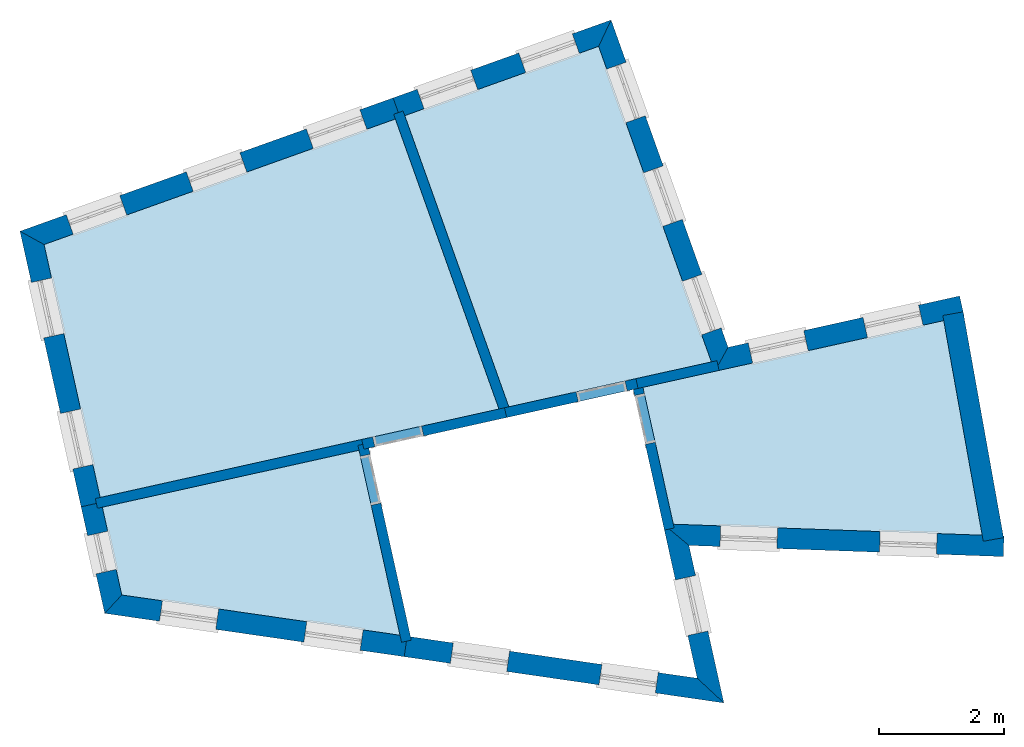
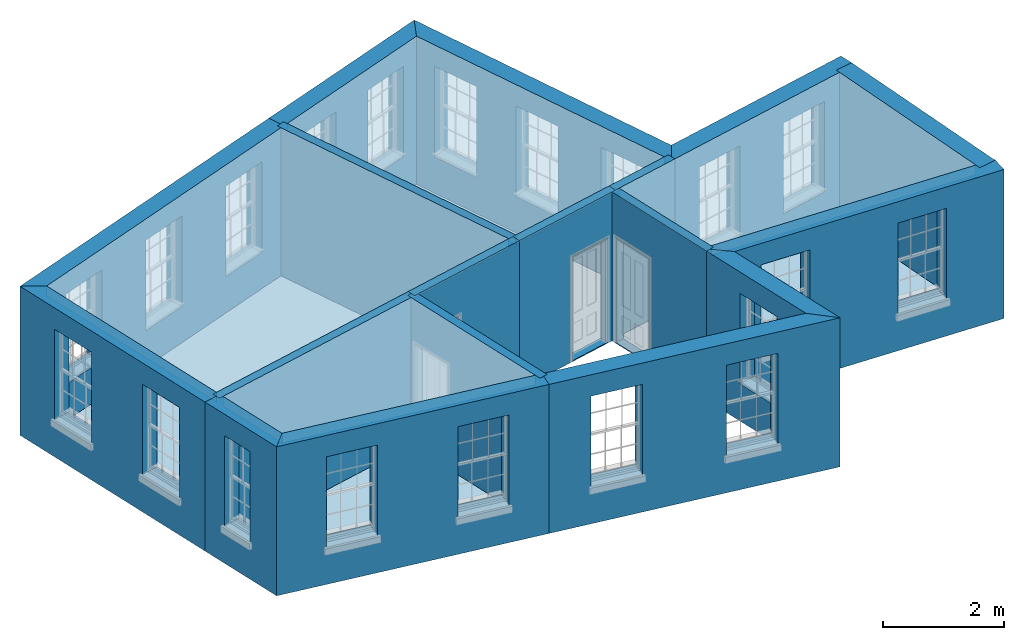
# One storey, part 1 of 10: 18 walls, 8 slabs, 24 openings.
"""IFC2X3 building model written with IfcOpenShell, lengths in metres."""

from ifc_helpers import new_model, si_unit, frame, origin, place, context, subcontext, project, spatial, polyline, outline, extrude, material, layer, layer_set, layer_usage, element, save


model = new_model("IFC2X3")

# Units and contexts
model_context = context("Model", 3, world=origin())
body_context = subcontext(model_context, "Body", "Model", "MODEL_VIEW")
ifc_project = project(units=[si_unit("PLANEANGLEUNIT", "RADIAN"), si_unit("MASSUNIT", "GRAM", prefix="KILO"), si_unit("FORCEUNIT", "NEWTON", prefix="KILO"), si_unit("LENGTHUNIT", "METRE")], contexts=[model_context])

# Site, building, storey
site_placement = place(None, origin())
site = spatial("IfcSite", under=ifc_project, at=site_placement, CompositionType="ELEMENT")
building_placement = place(None, origin())
building = spatial("IfcBuilding", under=site, at=building_placement, Name="Building plot-16", CompositionType="ELEMENT")
storey_placement = place(None, frame((0.0, 0.0, 6.0)))
storey = spatial("IfcBuildingStorey", under=building, at=storey_placement, Name="Floor 1", CompositionType="ELEMENT", Elevation=6.0)

# Slabs
slab_1_placement = place(storey_placement, frame((0.0, 0.0, 2.8)))
element("IfcSlab", 1, at=slab_1_placement, inside=storey, Name="Slab", ObjectType="Slab", PredefinedType="FLOOR", context=body_context, shape_type="SweptSolid", body=[
    extrude(outline(polyline([(96.2866198222254, 35.3957755660827), (96.7722962804905, 33.2056967986451), (101.713566305505, 33.029896488782), (101.098558041472, 36.4628810722689), (96.2866198222254, 35.3957755660827)])), origin(), (0.0, 0.0, 1.0), 0.2),
])
slab_2_placement = place(storey_placement, frame((0.0, 0.0, 2.8)))
element("IfcSlab", 2, at=slab_2_placement, inside=storey, Name="Slab", ObjectType="Slab", PredefinedType="FLOOR", context=body_context, shape_type="SweptSolid", body=[
    extrude(outline(polyline([(94.1404528776861, 35.0837241435856), (97.3810072176828, 35.8023562668068), (95.5770005534573, 40.8505427478087), (92.4756885775016, 39.7422660441802), (94.1404528776861, 35.0837241435856)])), origin(), (0.0, 0.0, 1.0), 0.2),
])
slab_3_placement = place(storey_placement, frame((0.0, 0.0, 2.8)))
element("IfcSlab", 3, at=slab_3_placement, inside=storey, Name="Slab", ObjectType="Slab", PredefinedType="FLOOR", context=body_context, shape_type="SweptSolid", body=[
    extrude(outline(polyline([(87.6024611335815, 33.6338453896089), (93.9830197157487, 35.0488114355862), (92.3250201117694, 39.6884235569242), (86.7051504212186, 37.6801216821844), (87.6024611335815, 33.6338453896089)])), origin(), (0.0, 0.0, 1.0), 0.2),
])
slab_4_placement = place(storey_placement, frame((0.0, 0.0, 2.8)))
element("IfcSlab", 4, at=slab_4_placement, inside=storey, Name="Slab", ObjectType="Slab", PredefinedType="FLOOR", context=body_context, shape_type="SweptSolid", body=[
    extrude(outline(polyline([(91.7432052171659, 34.3882184194522), (87.637101511753, 33.4776402546096), (87.9484434240576, 32.0736946856034), (92.3993213504913, 31.4295697385958), (91.7432052171659, 34.3882184194522)])), origin(), (0.0, 0.0, 1.0), 0.2),
])
slab_5_placement = place(storey_placement, origin())
element("IfcSlab", 5, at=slab_5_placement, inside=storey, Name="Slab", ObjectType="Slab", PredefinedType="FLOOR", context=body_context, shape_type="SweptSolid", body=[
    extrude(outline(polyline([(96.2866198222254, 35.3957755660827), (96.7722962804905, 33.2056967986451), (101.713566305505, 33.029896488782), (101.098558041472, 36.4628810722689), (96.2866198222254, 35.3957755660827)])), origin(), (0.0, 0.0, 1.0), 0.02),
])
slab_6_placement = place(storey_placement, origin())
element("IfcSlab", 6, at=slab_6_placement, inside=storey, Name="Slab", ObjectType="Slab", PredefinedType="FLOOR", context=body_context, shape_type="SweptSolid", body=[
    extrude(outline(polyline([(94.1404528776861, 35.0837241435856), (97.3810072176828, 35.8023562668068), (95.5770005534573, 40.8505427478087), (92.4756885775016, 39.7422660441802), (94.1404528776861, 35.0837241435856)])), origin(), (0.0, 0.0, 1.0), 0.02),
])
slab_7_placement = place(storey_placement, origin())
element("IfcSlab", 7, at=slab_7_placement, inside=storey, Name="Slab", ObjectType="Slab", PredefinedType="FLOOR", context=body_context, shape_type="SweptSolid", body=[
    extrude(outline(polyline([(87.6024611335815, 33.6338453896089), (93.9830197157487, 35.0488114355862), (92.3250201117694, 39.6884235569242), (86.7051504212186, 37.6801216821844), (87.6024611335815, 33.6338453896089)])), origin(), (0.0, 0.0, 1.0), 0.02),
])
slab_8_placement = place(storey_placement, origin())
element("IfcSlab", 8, at=slab_8_placement, inside=storey, Name="Slab", ObjectType="Slab", PredefinedType="FLOOR", context=body_context, shape_type="SweptSolid", body=[
    extrude(outline(polyline([(91.7432052171659, 34.3882184194522), (87.637101511753, 33.4776402546096), (87.9484434240576, 32.0736946856034), (92.3993213504913, 31.4295697385958), (91.7432052171659, 34.3882184194522)])), origin(), (0.0, 0.0, 1.0), 0.02),
])

# Wall, openings
ifc_material_1 = material(Name="Masonry")
ifc_layer_1 = layer(ifc_material_1, 0.33, ventilated=False)
ifc_layer_set_1 = layer_set([ifc_layer_1], Name="My Wall")
ifc_layer_usage_1 = layer_usage(ifc_layer_set_1, "AXIS2", "NEGATIVE", 0.08)
wall_1_placement = place(storey_placement, origin())
wall_1 = element("IfcWallStandardCase", 9, at=wall_1_placement, inside=storey, material=ifc_layer_usage_1, Name="exterior", context=body_context, shape_type="SweptSolid", body=[
    extrude(outline(polyline([(101.423997894318, 36.5350512962164), (101.35255211434, 36.8572243871524), (97.6480557261626, 36.0357075028211), (97.435272994639, 35.6505033013804), (101.423997894318, 36.5350512962164)])), origin(), (0.0, 0.0, 1.0), 3.0),
])
opening_1_placement = place(storey_placement, frame((0.0, 0.0, 0.75)))
element("IfcOpeningElement", 10, at=opening_1_placement, cuts=wall_1, Name="Opening", ObjectType="Opening", context=body_context, shape_type="SweptSolid", body=[
    extrude(outline(polyline([(100.695978200438, 36.7116211797089), (99.8075614951299, 36.5146040288589), (99.8790072751085, 36.1924309379229), (100.767423980417, 36.3894480887729), (100.695978200438, 36.7116211797089)])), origin(), (0.0, 0.0, 1.0), 1.82),
])
opening_2_placement = place(storey_placement, frame((0.0, 0.0, 0.75)))
element("IfcOpeningElement", 11, at=opening_2_placement, cuts=wall_1, Name="Opening", ObjectType="Opening", context=body_context, shape_type="SweptSolid", body=[
    extrude(outline(polyline([(98.8581029531051, 36.304050112344), (97.9696862477967, 36.107032961494), (98.0411320277753, 35.784859870558), (98.9295487330837, 35.981877021408), (98.8581029531051, 36.304050112344)])), origin(), (0.0, 0.0, 1.0), 1.82),
])

wall_2_placement = place(storey_placement, origin())
wall_2 = element("IfcWallStandardCase", 12, at=wall_2_placement, inside=storey, material=ifc_layer_usage_1, Name="exterior", context=body_context, shape_type="SweptSolid", body=[
    extrude(outline(polyline([(97.435272994639, 35.6505033013804), (97.6480557261626, 36.0357075028211), (95.7767041340643, 41.2723465883469), (95.5770005534573, 40.8505427478087), (97.435272994639, 35.6505033013804)])), origin(), (0.0, 0.0, 1.0), 3.0),
])
opening_3_placement = place(storey_placement, frame((0.0, 0.0, 0.75)))
element("IfcOpeningElement", 13, at=opening_3_placement, cuts=wall_2, Name="Opening", ObjectType="Opening", context=body_context, shape_type="SweptSolid", body=[
    extrude(outline(polyline([(97.5371926148935, 36.3459378753852), (97.2309634686248, 37.2028647742368), (96.9202097580522, 37.0918146442713), (97.2264389043209, 36.2348877454196), (97.5371926148935, 36.3459378753852)])), origin(), (0.0, 0.0, 1.0), 1.82),
])
opening_4_placement = place(storey_placement, frame((0.0, 0.0, 0.75)))
element("IfcOpeningElement", 14, at=opening_4_placement, cuts=wall_2, Name="Opening", ObjectType="Opening", context=body_context, shape_type="SweptSolid", body=[
    extrude(outline(polyline([(96.9167115667487, 38.0822419041217), (96.61048242048, 38.9391688029733), (96.2997287099074, 38.8281186730078), (96.6059578561762, 37.9711917741561), (96.9167115667487, 38.0822419041217)])), origin(), (0.0, 0.0, 1.0), 1.82),
])
opening_5_placement = place(storey_placement, frame((0.0, 0.0, 0.75)))
element("IfcOpeningElement", 15, at=opening_5_placement, cuts=wall_2, Name="Opening", ObjectType="Opening", context=body_context, shape_type="SweptSolid", body=[
    extrude(outline(polyline([(96.3241881176086, 39.7403116468463), (96.0179589713399, 40.5972385456979), (95.7072052607673, 40.4861884157324), (96.013434407036, 39.6292615168807), (96.3241881176086, 39.7403116468463)])), origin(), (0.0, 0.0, 1.0), 1.82),
])

wall_3_placement = place(storey_placement, origin())
wall_3 = element("IfcWallStandardCase", 16, at=wall_3_placement, inside=storey, material=ifc_layer_usage_1, Name="exterior", context=body_context, shape_type="SweptSolid", body=[
    extrude(outline(polyline([(95.5770005534573, 40.8505427478087), (95.7767041340643, 41.2723465883469), (92.2893042146699, 40.0260985111248), (92.4003543446355, 39.7153448005522), (95.5770005534573, 40.8505427478087)])), origin(), (0.0, 0.0, 1.0), 3.0),
])
opening_6_placement = place(storey_placement, frame((0.0, 0.0, 0.75)))
element("IfcOpeningElement", 17, at=opening_6_placement, cuts=wall_3, Name="Opening", ObjectType="Opening", context=body_context, shape_type="SweptSolid", body=[
    extrude(outline(polyline([(95.1567529953617, 41.0508024774225), (94.29982609651, 40.7445733311538), (94.4108762264756, 40.4338196205812), (95.2678031253273, 40.74004876685), (95.1567529953617, 41.0508024774225)])), origin(), (0.0, 0.0, 1.0), 1.82),
])
opening_7_placement = place(storey_placement, frame((0.0, 0.0, 0.75)))
element("IfcOpeningElement", 18, at=opening_7_placement, cuts=wall_3, Name="Opening", ObjectType="Opening", context=body_context, shape_type="SweptSolid", body=[
    extrude(outline(polyline([(93.5307627745177, 40.4697428819803), (92.6738358756661, 40.1635137357116), (92.7848860056317, 39.852760025139), (93.6418129044833, 40.1589891714077), (93.5307627745177, 40.4697428819803)])), origin(), (0.0, 0.0, 1.0), 1.82),
])

wall_4_placement = place(storey_placement, origin())
wall_4 = element("IfcWallStandardCase", 19, at=wall_4_placement, inside=storey, material=ifc_layer_usage_1, Name="exterior", context=body_context, shape_type="SweptSolid", body=[
    extrude(outline(polyline([(92.4003543446355, 39.7153448005522), (92.2893042146699, 40.0260985111248), (86.3199462197779, 37.892904413708), (86.7051504212186, 37.6801216821844), (92.4003543446355, 39.7153448005522)])), origin(), (0.0, 0.0, 1.0), 3.0),
])
opening_8_placement = place(storey_placement, frame((0.0, 0.0, 0.75)))
element("IfcOpeningElement", 20, at=opening_8_placement, cuts=wall_4, Name="Opening", ObjectType="Opening", context=body_context, shape_type="SweptSolid", body=[
    extrude(outline(polyline([(91.7574900780122, 39.8360508078019), (90.9005631791605, 39.5298216615332), (91.0116133091261, 39.2190679509606), (91.8685402079777, 39.5252970972293), (91.7574900780122, 39.8360508078019)])), origin(), (0.0, 0.0, 1.0), 1.82),
])
opening_9_placement = place(storey_placement, frame((0.0, 0.0, 0.75)))
element("IfcOpeningElement", 21, at=opening_9_placement, cuts=wall_4, Name="Opening", ObjectType="Opening", context=body_context, shape_type="SweptSolid", body=[
    extrude(outline(polyline([(89.8369349058449, 39.1497262548875), (88.9800080069932, 38.8434971086188), (89.0910581369588, 38.5327433980462), (89.9479850358105, 38.8389725443149), (89.8369349058449, 39.1497262548875)])), origin(), (0.0, 0.0, 1.0), 1.82),
])
opening_10_placement = place(storey_placement, frame((0.0, 0.0, 0.75)))
element("IfcOpeningElement", 22, at=opening_10_placement, cuts=wall_4, Name="Opening", ObjectType="Opening", context=body_context, shape_type="SweptSolid", body=[
    extrude(outline(polyline([(87.9163797336776, 38.4634017019731), (87.0594528348259, 38.1571725557044), (87.1705029647915, 37.8464188451318), (88.0274298636432, 38.1526479914005), (87.9163797336776, 38.4634017019731)])), origin(), (0.0, 0.0, 1.0), 1.82),
])

wall_5_placement = place(storey_placement, origin())
wall_5 = element("IfcWallStandardCase", 23, at=wall_5_placement, inside=storey, material=ifc_layer_usage_1, Name="exterior", context=body_context, shape_type="SweptSolid", body=[
    extrude(outline(polyline([(86.7051504212186, 37.6801216821844), (86.3199462197779, 37.892904413708), (87.2976082317312, 33.4842970421306), (87.6197813226672, 33.5557428221092), (86.7051504212186, 37.6801216821844)])), origin(), (0.0, 0.0, 1.0), 3.0),
])
opening_11_placement = place(storey_placement, frame((0.0, 0.0, 0.75)))
element("IfcOpeningElement", 24, at=opening_11_placement, cuts=wall_5, Name="Opening", ObjectType="Opening", context=body_context, shape_type="SweptSolid", body=[
    extrude(outline(polyline([(86.5016662783098, 37.0734674510234), (86.6986834291598, 36.1850507457151), (87.0208565200958, 36.2564965256937), (86.8238393692458, 37.144913231002), (86.5016662783098, 37.0734674510234)])), origin(), (0.0, 0.0, 1.0), 1.82),
])
opening_12_placement = place(storey_placement, frame((0.0, 0.0, 0.75)))
element("IfcOpeningElement", 25, at=opening_12_placement, cuts=wall_5, Name="Opening", ObjectType="Opening", context=body_context, shape_type="SweptSolid", body=[
    extrude(outline(polyline([(86.9666218636407, 34.9768260801977), (87.1636390144908, 34.0884093748893), (87.4858121054268, 34.1598551548679), (87.2887949545767, 35.0482718601763), (86.9666218636407, 34.9768260801977)])), origin(), (0.0, 0.0, 1.0), 1.82),
])

# Wall, opening
wall_6_placement = place(storey_placement, origin())
wall_6 = element("IfcWallStandardCase", 26, at=wall_6_placement, inside=storey, material=ifc_layer_usage_1, Name="exterior", context=body_context, shape_type="SweptSolid", body=[
    extrude(outline(polyline([(87.6197813226672, 33.5557428221092), (87.2976082317312, 33.4842970421306), (87.6756142911979, 31.7797403754188), (87.9484434240576, 32.0736946856034), (87.6197813226672, 33.5557428221092)])), origin(), (0.0, 0.0, 1.0), 3.0),
])
opening_13_placement = place(storey_placement, frame((0.0, 0.0, 0.75)))
element("IfcOpeningElement", 27, at=opening_13_placement, cuts=wall_6, Name="Opening", ObjectType="Opening", context=body_context, shape_type="SweptSolid", body=[
    extrude(outline(polyline([(87.4002633796378, 33.0213903972391), (87.5355773568699, 32.4112140886482), (87.8577504478059, 32.4826598686268), (87.7224364705738, 33.0928361772177), (87.4002633796378, 33.0213903972391)])), origin(), (0.0, 0.0, 1.0), 1.82),
])

# Wall, openings
wall_7_placement = place(storey_placement, origin())
wall_7 = element("IfcWallStandardCase", 28, at=wall_7_placement, inside=storey, material=ifc_layer_usage_1, Name="exterior", context=body_context, shape_type="SweptSolid", body=[
    extrude(outline(polyline([(87.9484434240576, 32.0736946856034), (87.6756142911979, 31.7797403754188), (92.4666954104416, 31.086381689099), (92.513960177979, 31.4129793647637), (87.9484434240576, 32.0736946856034)])), origin(), (0.0, 0.0, 1.0), 3.0),
])
opening_14_placement = place(storey_placement, frame((0.0, 0.0, 0.75)))
element("IfcOpeningElement", 29, at=opening_14_placement, cuts=wall_7, Name="Opening", ObjectType="Opening", context=body_context, shape_type="SweptSolid", body=[
    extrude(outline(polyline([(88.5512372257678, 31.653021425663), (89.4518550586615, 31.5226852485144), (89.4991198261989, 31.8492829241791), (88.5985019933052, 31.9796191013278), (88.5512372257678, 31.653021425663)])), origin(), (0.0, 0.0, 1.0), 1.82),
])
opening_15_placement = place(storey_placement, frame((0.0, 0.0, 0.75)))
element("IfcOpeningElement", 30, at=opening_15_placement, cuts=wall_7, Name="Opening", ObjectType="Opening", context=body_context, shape_type="SweptSolid", body=[
    extrude(outline(polyline([(90.861336737919, 31.3187069936699), (91.7619545708128, 31.1883708165212), (91.8092193383502, 31.514968492186), (90.9086015054565, 31.6453046693347), (90.861336737919, 31.3187069936699)])), origin(), (0.0, 0.0, 1.0), 1.82),
])

wall_8_placement = place(storey_placement, origin())
wall_8 = element("IfcWallStandardCase", 31, at=wall_8_placement, inside=storey, material=ifc_layer_usage_1, Name="exterior", context=body_context, shape_type="SweptSolid", body=[
    extrude(outline(polyline([(92.513960177979, 31.4129793647637), (92.4666954104416, 31.086381689099), (97.5805288405461, 30.3463147311604), (97.1549084446968, 30.7413476988825), (92.513960177979, 31.4129793647637)])), origin(), (0.0, 0.0, 1.0), 3.0),
])
opening_16_placement = place(storey_placement, frame((0.0, 0.0, 0.75)))
element("IfcOpeningElement", 32, at=opening_16_placement, cuts=wall_8, Name="Opening", ObjectType="Opening", context=body_context, shape_type="SweptSolid", body=[
    extrude(outline(polyline([(93.2052832675461, 30.979494267745), (94.1059011004399, 30.8491580905963), (94.1531658679773, 31.1757557662611), (93.2525480350835, 31.3060919434098), (93.2052832675461, 30.979494267745)])), origin(), (0.0, 0.0, 1.0), 1.82),
])
opening_17_placement = place(storey_placement, frame((0.0, 0.0, 0.75)))
element("IfcOpeningElement", 33, at=opening_17_placement, cuts=wall_8, Name="Opening", ObjectType="Opening", context=body_context, shape_type="SweptSolid", body=[
    extrude(outline(polyline([(95.5830768146488, 30.6353832478883), (96.4836946475426, 30.5050470707397), (96.53095941508, 30.8316447464044), (95.6303415821863, 30.9619809235531), (95.5830768146488, 30.6353832478883)])), origin(), (0.0, 0.0, 1.0), 1.82),
])

# Wall, opening
wall_9_placement = place(storey_placement, origin())
wall_9 = element("IfcWallStandardCase", 34, at=wall_9_placement, inside=storey, material=ifc_layer_usage_1, Name="exterior", context=body_context, shape_type="SweptSolid", body=[
    extrude(outline(polyline([(97.1549084446968, 30.7413476988825), (97.5805288405461, 30.3463147311604), (97.0216212073761, 32.8666175367297), (96.607105896403, 33.2115739356083), (97.1549084446968, 30.7413476988825)])), origin(), (0.0, 0.0, 1.0), 3.0),
])
opening_18_placement = place(storey_placement, frame((0.0, 0.0, 0.75)))
element("IfcOpeningElement", 35, at=opening_18_placement, cuts=wall_9, Name="Opening", ObjectType="Opening", context=body_context, shape_type="SweptSolid", body=[
    extrude(outline(polyline([(97.3254209005413, 31.496682374684), (97.1284037496912, 32.3850990799923), (96.8062306587552, 32.3136533000138), (97.0032478096053, 31.4252365947054), (97.3254209005413, 31.496682374684)])), origin(), (0.0, 0.0, 1.0), 1.82),
])

# Wall, openings
wall_10_placement = place(storey_placement, origin())
wall_10 = element("IfcWallStandardCase", 36, at=wall_10_placement, inside=storey, material=ifc_layer_usage_1, Name="exterior", context=body_context, shape_type="SweptSolid", body=[
    extrude(outline(polyline([(96.607105896403, 33.2115739356083), (97.0216212073761, 32.8666175367297), (102.050747108567, 32.6876914939727), (102.06248041193, 33.0174828364791), (96.607105896403, 33.2115739356083)])), origin(), (0.0, 0.0, 1.0), 3.0),
])
opening_19_placement = place(storey_placement, frame((0.0, 0.0, 0.75)))
element("IfcOpeningElement", 37, at=opening_19_placement, cuts=wall_10, Name="Opening", ObjectType="Opening", context=body_context, shape_type="SweptSolid", body=[
    extrude(outline(polyline([(97.5195431828704, 32.8489024883441), (98.4289677940245, 32.8165470154335), (98.4407010973877, 33.14633835794), (97.5312764862336, 33.1786938308505), (97.5195431828704, 32.8489024883441)])), origin(), (0.0, 0.0, 1.0), 1.82),
])
opening_20_placement = place(storey_placement, frame((0.0, 0.0, 0.75)))
element("IfcOpeningElement", 38, at=opening_20_placement, cuts=wall_10, Name="Opening", ObjectType="Opening", context=body_context, shape_type="SweptSolid", body=[
    extrude(outline(polyline([(100.070642978856, 32.7581395605228), (100.98006759001, 32.7257840876123), (100.991800893373, 33.0555754301187), (100.082376282219, 33.0879309030292), (100.070642978856, 32.7581395605228)])), origin(), (0.0, 0.0, 1.0), 1.82),
])

# Wall
wall_11_placement = place(storey_placement, origin())
element("IfcWallStandardCase", 39, at=wall_11_placement, inside=storey, material=ifc_layer_usage_1, Name="party", context=body_context, shape_type="SweptSolid", body=[
    extrude(outline(polyline([(101.731047695816, 32.9323151277738), (102.055876401091, 32.9905071566866), (101.408689534277, 36.6031131432117), (101.083860829002, 36.5449211142989), (101.731047695816, 32.9323151277738)])), origin(), (0.0, 0.0, 1.0), 3.0),
])

# Wall, opening
ifc_material_2 = material(Name="Masonry")
ifc_layer_2 = layer(ifc_material_2, 0.16, ventilated=False)
ifc_layer_set_2 = layer_set([ifc_layer_2], Name="My Wall")
ifc_layer_usage_2 = layer_usage(ifc_layer_set_2, "AXIS2", "NEGATIVE", 0.08)
wall_12_placement = place(storey_placement, origin())
wall_12 = element("IfcWallStandardCase", 40, at=wall_12_placement, inside=storey, material=ifc_layer_usage_2, Name="interior", context=body_context, shape_type="SweptSolid", body=[
    extrude(outline(polyline([(96.6294918891393, 33.110627952855), (96.7856970241385, 33.1452683310264), (96.2692996331396, 35.4738781335823), (96.1130944981404, 35.4392377554109), (96.6294918891393, 33.110627952855)])), origin(), (0.0, 0.0, 1.0), 3.0),
])
opening_21_placement = place(storey_placement, frame((0.0, 0.0, 0.0199999999999996)))
element("IfcOpeningElement", 41, at=opening_21_placement, cuts=wall_12, Name="Opening", ObjectType="Opening", context=body_context, shape_type="SweptSolid", body=[
    extrude(outline(polyline([(96.4814719494397, 34.5171216817118), (96.3082700585825, 35.2981473567081), (96.1520649235832, 35.2635069785367), (96.3252668144404, 34.4824813035404), (96.4814719494397, 34.5171216817118)])), origin(), (0.0, 0.0, 1.0), 2.1),
])

# Wall
wall_13_placement = place(storey_placement, origin())
element("IfcWallStandardCase", 42, at=wall_13_placement, inside=storey, material=ifc_layer_usage_2, Name="interior", context=body_context, shape_type="SweptSolid", body=[
    extrude(outline(polyline([(96.1738768765543, 35.5346605119962), (96.2085172547257, 35.378455376997), (97.5041768762153, 35.6657835705937), (97.4695364980439, 35.8219887055929), (96.1738768765543, 35.5346605119962)])), origin(), (0.0, 0.0, 1.0), 3.0),
])

# Wall, opening
wall_14_placement = place(storey_placement, origin())
wall_14 = element("IfcWallStandardCase", 43, at=wall_14_placement, inside=storey, material=ifc_layer_usage_2, Name="interior", context=body_context, shape_type="SweptSolid", body=[
    extrude(outline(polyline([(94.0715489961098, 35.0684438743723), (94.1061893742812, 34.9122387393731), (96.2085172547257, 35.378455376997), (96.1738768765543, 35.5346605119962), (94.0715489961098, 35.0684438743723)])), origin(), (0.0, 0.0, 1.0), 3.0),
])
opening_22_placement = place(storey_placement, frame((0.0, 0.0, 0.0199999999999996)))
element("IfcOpeningElement", 44, at=opening_22_placement, cuts=wall_14, Name="Opening", ObjectType="Opening", context=body_context, shape_type="SweptSolid", body=[
    extrude(outline(polyline([(95.2517608028552, 35.1662830606969), (96.0327864778515, 35.3394849515541), (95.9981460996801, 35.4956900865534), (95.2171204246837, 35.3224881956962), (95.2517608028552, 35.1662830606969)])), origin(), (0.0, 0.0, 1.0), 2.1),
])

wall_15_placement = place(storey_placement, origin())
wall_15 = element("IfcWallStandardCase", 45, at=wall_15_placement, inside=storey, material=ifc_layer_usage_2, Name="interior", context=body_context, shape_type="SweptSolid", body=[
    extrude(outline(polyline([(91.8820901630794, 34.5009613651233), (91.7258850280802, 34.4663209869519), (92.4243994850158, 31.3164839815775), (92.580604620015, 31.3511243597489), (91.8820901630794, 34.5009613651233)])), origin(), (0.0, 0.0, 1.0), 3.0),
])
opening_23_placement = place(storey_placement, frame((0.0, 0.0, 0.0199999999999996)))
element("IfcOpeningElement", 46, at=opening_23_placement, cuts=wall_15, Name="Opening", ObjectType="Opening", context=body_context, shape_type="SweptSolid", body=[
    extrude(outline(polyline([(91.764855453523, 34.2905902100777), (91.9380573443802, 33.5095645350814), (92.0942624793795, 33.5442049132528), (91.9210605885223, 34.3252305882491), (91.764855453523, 34.2905902100777)])), origin(), (0.0, 0.0, 1.0), 2.1),
])

# Walls
wall_16_placement = place(storey_placement, origin())
element("IfcWallStandardCase", 47, at=wall_16_placement, inside=storey, material=ifc_layer_usage_2, Name="interior", context=body_context, shape_type="SweptSolid", body=[
    extrude(outline(polyline([(91.8213077846655, 34.405538608538), (91.7866674064941, 34.5617437435372), (87.5243585660819, 33.6165252005231), (87.5589989442533, 33.4603200655239), (91.8213077846655, 34.405538608538)])), origin(), (0.0, 0.0, 1.0), 3.0),
])
wall_17_placement = place(storey_placement, origin())
element("IfcWallStandardCase", 48, at=wall_17_placement, inside=storey, material=ifc_layer_usage_2, Name="interior", context=body_context, shape_type="SweptSolid", body=[
    extrude(outline(polyline([(94.0135349523294, 34.9634200632447), (94.1642034180616, 35.0172625505007), (92.4487673338736, 39.8176002770463), (92.2980988681414, 39.7637577897903), (94.0135349523294, 34.9634200632447)])), origin(), (0.0, 0.0, 1.0), 3.0),
])

# Wall, opening
wall_18_placement = place(storey_placement, origin())
wall_18 = element("IfcWallStandardCase", 49, at=wall_18_placement, inside=storey, material=ifc_layer_usage_2, Name="interior", context=body_context, shape_type="SweptSolid", body=[
    extrude(outline(polyline([(94.1061893742812, 34.9122387393731), (94.0715489961098, 35.0684438743723), (91.7866674064941, 34.5617437435372), (91.8213077846655, 34.405538608538), (94.1061893742812, 34.9122387393731)])), origin(), (0.0, 0.0, 1.0), 3.0),
])
opening_24_placement = place(storey_placement, frame((0.0, 0.0, 0.0199999999999996)))
element("IfcOpeningElement", 50, at=opening_24_placement, cuts=wall_18, Name="Opening", ObjectType="Opening", context=body_context, shape_type="SweptSolid", body=[
    extrude(outline(polyline([(92.7434238583646, 34.7739160598373), (91.9623981833683, 34.6007141689801), (91.9970385615397, 34.4445090339808), (92.778064236536, 34.617710924838), (92.7434238583646, 34.7739160598373)])), origin(), (0.0, 0.0, 1.0), 2.1),
])

save(model, "model.ifc")
